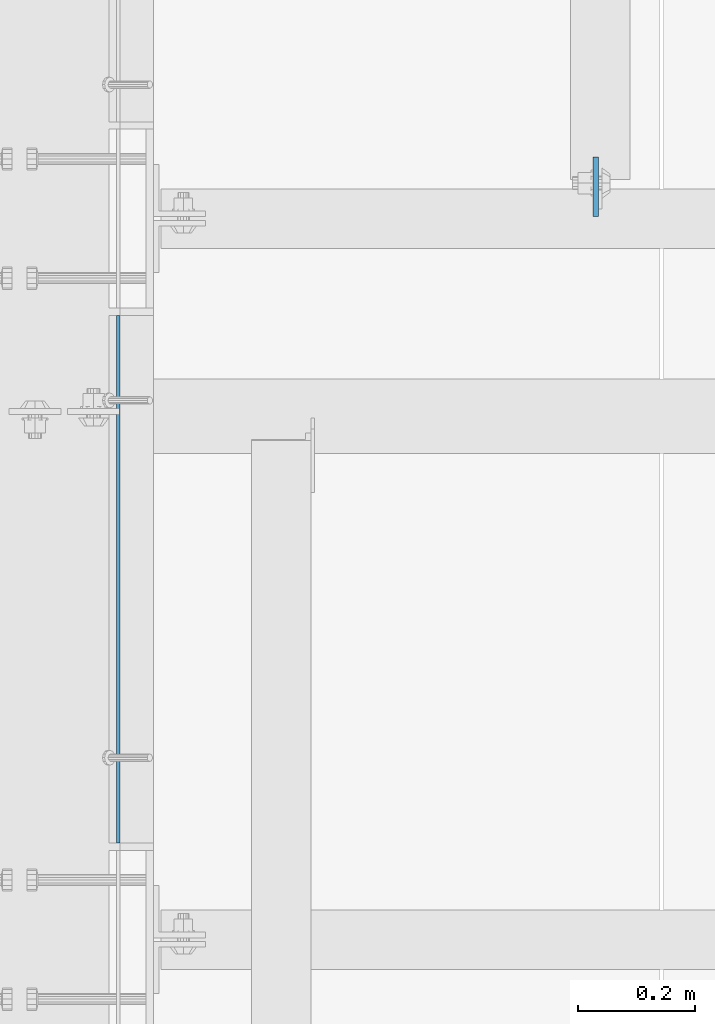
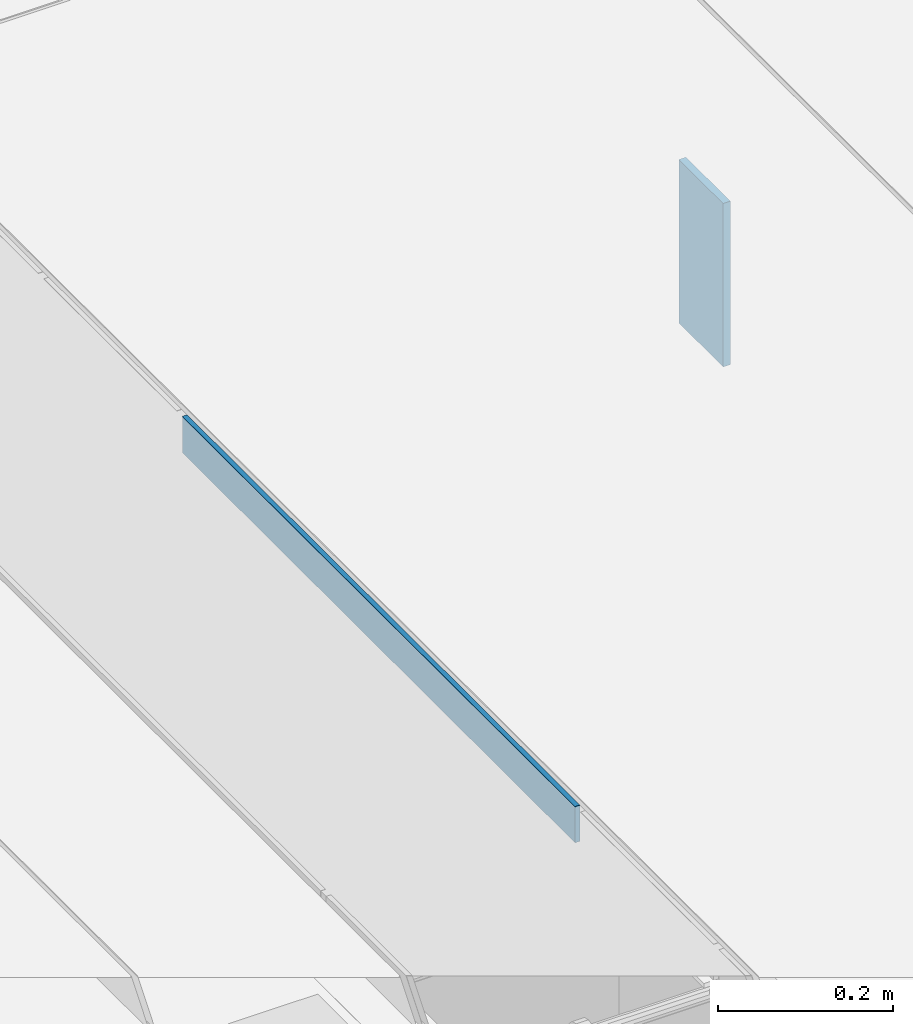
# One storey, part 3166 of 3843: 2 plates, 2 elements without a shape of their own.
"""IFC2X3 building model written with IfcOpenShell, lengths in millimetres."""

from ifc_helpers import new_model, si_unit, frame, origin_with_axes, place, context, subcontext, project, spatial, faceted_brep, material, type_object, element, aggregate, save


model = new_model("IFC2X3")

# Units and contexts
model_context = context("Model", 3, precision=1e-05, world=origin_with_axes())
body_context = subcontext(model_context, "Body", "Model", "MODEL_VIEW")
ifc_project = project(units=[si_unit("LENGTHUNIT", "METRE", prefix="MILLI"), si_unit("AREAUNIT", "SQUARE_METRE"), si_unit("VOLUMEUNIT", "CUBIC_METRE"), si_unit("MASSUNIT", "GRAM", prefix="KILO"), si_unit("TIMEUNIT", "SECOND"), si_unit("PLANEANGLEUNIT", "RADIAN"), si_unit("SOLIDANGLEUNIT", "STERADIAN"), si_unit("THERMODYNAMICTEMPERATUREUNIT", "DEGREE_CELSIUS"), si_unit("LUMINOUSINTENSITYUNIT", "LUMEN")], contexts=[model_context])

# Site, building, storey
site_placement = place(None, origin_with_axes())
site = spatial("IfcSite", under=ifc_project, at=site_placement, CompositionType="ELEMENT")
building_placement = place(site_placement, origin_with_axes())
building = spatial("IfcBuilding", under=site, at=building_placement, Name="Undefined", CompositionType="ELEMENT")
storey_placement = place(building_placement, origin_with_axes())
storey = spatial("IfcBuildingStorey", under=building, at=storey_placement, Name="Undefined", CompositionType="ELEMENT", Elevation=0.0)

# Assembly, plate
assembly_1_placement = place(storey_placement, origin_with_axes())
assembly_1 = element("IfcElementAssembly", 1, at=assembly_1_placement, inside=storey, Name="ANGLE", AssemblyPlace="NOTDEFINED", PredefinedType="RIGID_FRAME")
ifc_material_1 = material(Name="STEEL/A36")
plate_type_1 = type_object("IfcPlateType", PredefinedType="NOTDEFINED")
plate_1_placement = place(assembly_1_placement, frame((62728.4749880221, 16394.1123981715, 30429.2000030518), z_axis=(0.0, 0.999999999997942, -2.02899998962774e-06), x_axis=(0.0, 2.02899999567308e-06, 0.999999999997942)))
plate_1 = element("IfcPlate", 2, at=plate_1_placement, type_object=plate_type_1, material=ifc_material_1, Name="PLATE", context=body_context, shape_type="Brep", body=[
    faceted_brep([(0.0, -3.17499999999927, 0.0), (0.00181156927283155, -3.1749999984022, 900.111999510274), (0.00181156927283155, 3.17500000159635, 900.11199951026), (0.0, 3.17499999999927, 0.0), (50.8018112192949, -3.1749999984022, 900.111999510213), (50.8018112192949, 3.17500000159635, 900.111999510198), (50.7999954217848, -3.17499999999563, -7.27595761418343e-12), (50.7999954217848, 3.17500000001019, -1.09139364212751e-11)], [[[0, 1, 2, 3]], [[1, 4, 5, 2]], [[4, 6, 7, 5]], [[6, 0, 3, 7]], [[5, 7, 3, 2]], [[6, 4, 1, 0]]]),
])
aggregate(assembly_1, [plate_1])

assembly_2_placement = place(storey_placement, origin_with_axes())
assembly_2 = element("IfcElementAssembly", 3, at=assembly_2_placement, inside=storey, Name="BEAM", AssemblyPlace="NOTDEFINED", PredefinedType="RIGID_FRAME")
ifc_material_2 = material(Name="STEEL/A572-50")
plate_type_2 = type_object("IfcPlateType", PredefinedType="NOTDEFINED")
plate_2_placement = place(assembly_2_placement, frame((63542.8625, 17462.5, 30391.1), z_axis=(0.0, 1.0, 0.0), x_axis=(0.0, 0.0, -1.0)))
plate_2 = element("IfcPlate", 4, at=plate_2_placement, type_object=plate_type_2, material=ifc_material_2, Name="PLATE", context=body_context, shape_type="Brep", body=[
    faceted_brep([(0.0, -4.76249999999709, 0.0), (0.0, -4.76249999999709, 101.599999999999), (0.0, 4.76249999999709, 101.599999999999), (0.0, 4.76249999999709, 0.0), (228.600006103516, -4.76249999999709, 101.599998474121), (228.600006103516, 4.76249999999709, 101.599998474121), (228.600006103079, -4.7625000004482, 7.27595761418343e-12), (228.600006103079, 4.76249999954598, -7.27595761418343e-12)], [[[0, 1, 2, 3]], [[1, 4, 5, 2]], [[4, 6, 7, 5]], [[6, 0, 3, 7]], [[5, 7, 3, 2]], [[6, 4, 1, 0]]]),
])
aggregate(assembly_2, [plate_2])

save(model, "model.ifc")
